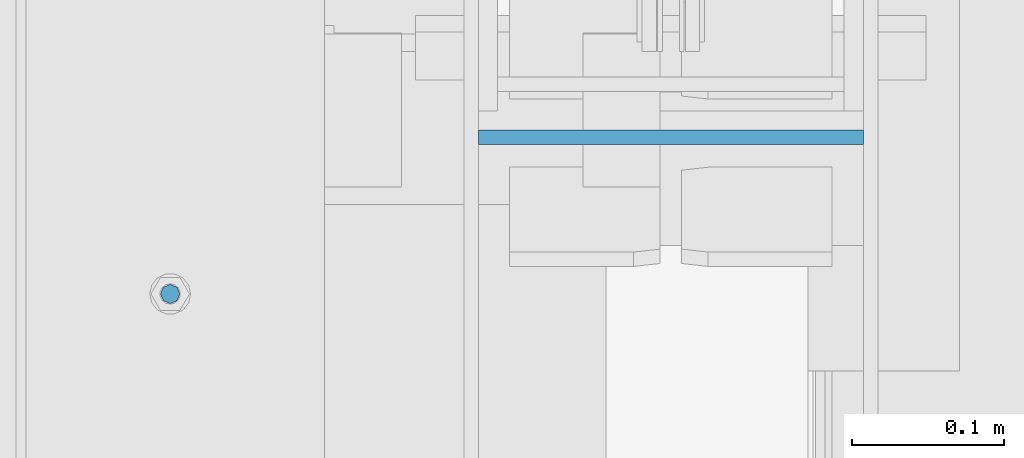
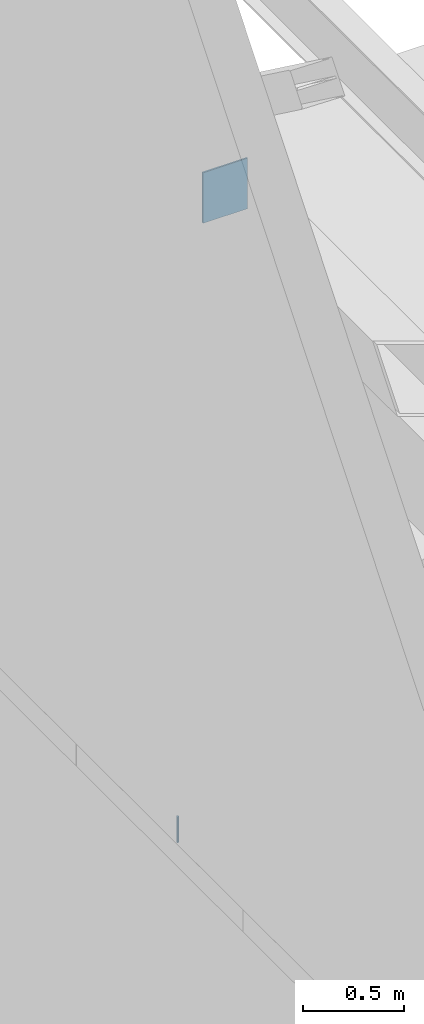
# One storey, part 416 of 1179: 2 columns, 2 elements without a shape of their own.
"""IFC2X3 building model written with IfcOpenShell, lengths in millimetres."""

from ifc_helpers import new_model, si_unit, frame, origin_with_axes, place, context, subcontext, project, spatial, faceted_brep, material, type_object, element, aggregate, save


model = new_model("IFC2X3")

# Units and contexts
model_context = context("Model", 3, precision=1e-05, world=origin_with_axes())
body_context = subcontext(model_context, "Body", "Model", "MODEL_VIEW")
ifc_project = project(units=[si_unit("LENGTHUNIT", "METRE", prefix="MILLI"), si_unit("AREAUNIT", "SQUARE_METRE"), si_unit("VOLUMEUNIT", "CUBIC_METRE"), si_unit("MASSUNIT", "GRAM", prefix="KILO"), si_unit("TIMEUNIT", "SECOND"), si_unit("PLANEANGLEUNIT", "RADIAN"), si_unit("SOLIDANGLEUNIT", "STERADIAN"), si_unit("THERMODYNAMICTEMPERATUREUNIT", "DEGREE_CELSIUS"), si_unit("LUMINOUSINTENSITYUNIT", "LUMEN")], contexts=[model_context])

# Site, building, storey
site_placement = place(None, origin_with_axes())
site = spatial("IfcSite", under=ifc_project, at=site_placement, CompositionType="ELEMENT")
building_placement = place(site_placement, origin_with_axes())
building = spatial("IfcBuilding", under=site, at=building_placement, Name="Undefined", CompositionType="ELEMENT")
storey_placement = place(building_placement, origin_with_axes())
storey = spatial("IfcBuildingStorey", under=building, at=storey_placement, Name="Undefined", CompositionType="ELEMENT", Elevation=0.0)

# Assembly, column
assembly_1_placement = place(storey_placement, origin_with_axes())
assembly_1 = element("IfcElementAssembly", 1, at=assembly_1_placement, inside=storey, Name="BEAM", AssemblyPlace="NOTDEFINED", PredefinedType="RIGID_FRAME")
ifc_material_1 = material(Name="STEEL/A307")
column_type_1 = type_object("IfcColumnType", PredefinedType="NOTDEFINED")
column_1_placement = place(assembly_1_placement, frame((101.599999999999, 18402.3, 4108.45), z_axis=(0.0, 1.0, 0.0), x_axis=(0.0, 0.0, 1.0)))
column_1 = element("IfcColumn", 2, at=column_1_placement, type_object=column_type_1, material=ifc_material_1, Name="THREADED ROD", context=body_context, shape_type="Brep", body=[
    faceted_brep([(0.0, -6.34999999999854, 0.0), (0.0, -4.49012806053361, -4.49012806053452), (157.162499999999, -4.49012806053361, -4.49012806053361), (157.162499999999, -6.34999999999854, 0.0), (0.0, 0.0, -6.34999999999991), (157.162499999999, 0.0, -6.34999999999854), (0.0, 4.49012806053361, -4.49012806053452), (157.162499999999, 4.49012806053361, -4.49012806053361), (0.0, 6.34999999999854, 0.0), (157.162499999999, 6.34999999999854, 0.0), (0.0, 4.49012806053361, 4.49012806053452), (157.162499999999, 4.49012806053361, 4.49012806053361), (0.0, 0.0, 6.34999999999991), (157.162499999999, 0.0, 6.34999999999854), (0.0, -4.49012806053361, 4.49012806053452), (157.162499999999, -4.49012806053361, 4.49012806053361)], [[[0, 1, 2, 3]], [[1, 4, 5, 2]], [[4, 6, 7, 5]], [[6, 8, 9, 7]], [[8, 10, 11, 9]], [[10, 12, 13, 11]], [[12, 14, 15, 13]], [[14, 0, 3, 15]], [[5, 7, 9, 11, 13, 15, 3, 2]], [[14, 12, 10, 8, 6, 4, 1, 0]]]),
])
aggregate(assembly_1, [column_1])

assembly_2_placement = place(storey_placement, origin_with_axes())
assembly_2 = element("IfcElementAssembly", 3, at=assembly_2_placement, inside=storey, Name="BEAM", AssemblyPlace="NOTDEFINED", PredefinedType="RIGID_FRAME")
ifc_material_2 = material(Name="STEEL/A36")
column_type_2 = type_object("IfcColumnType", PredefinedType="NOTDEFINED")
column_2_placement = place(assembly_2_placement, frame((431.800000000005, 18505.6623035139, 7708.9), z_axis=(-1.0, 0.0, 0.0), x_axis=(0.0, 0.0, 1.0)))
column_2 = element("IfcColumn", 4, at=column_2_placement, type_object=column_type_2, material=ifc_material_2, Name="PLATE", context=body_context, shape_type="Brep", body=[
    faceted_brep([(0.0, 4.76249999999982, -127.0), (0.0, 4.76249999999709, 127.0), (304.799999999999, 4.76249999999982, 127.0), (304.799999999999, 4.76249999999982, -127.0), (0.0, -4.76249999999709, 127.0), (304.799999999999, -4.76249999999982, 127.0), (0.0, -4.76249999999982, -127.0), (304.799999999999, -4.76249999999982, -127.0)], [[[0, 1, 2, 3]], [[1, 4, 5, 2]], [[4, 6, 7, 5]], [[6, 0, 3, 7]], [[5, 7, 3, 2]], [[6, 4, 1, 0]]]),
])
aggregate(assembly_2, [column_2])

save(model, "model.ifc")
